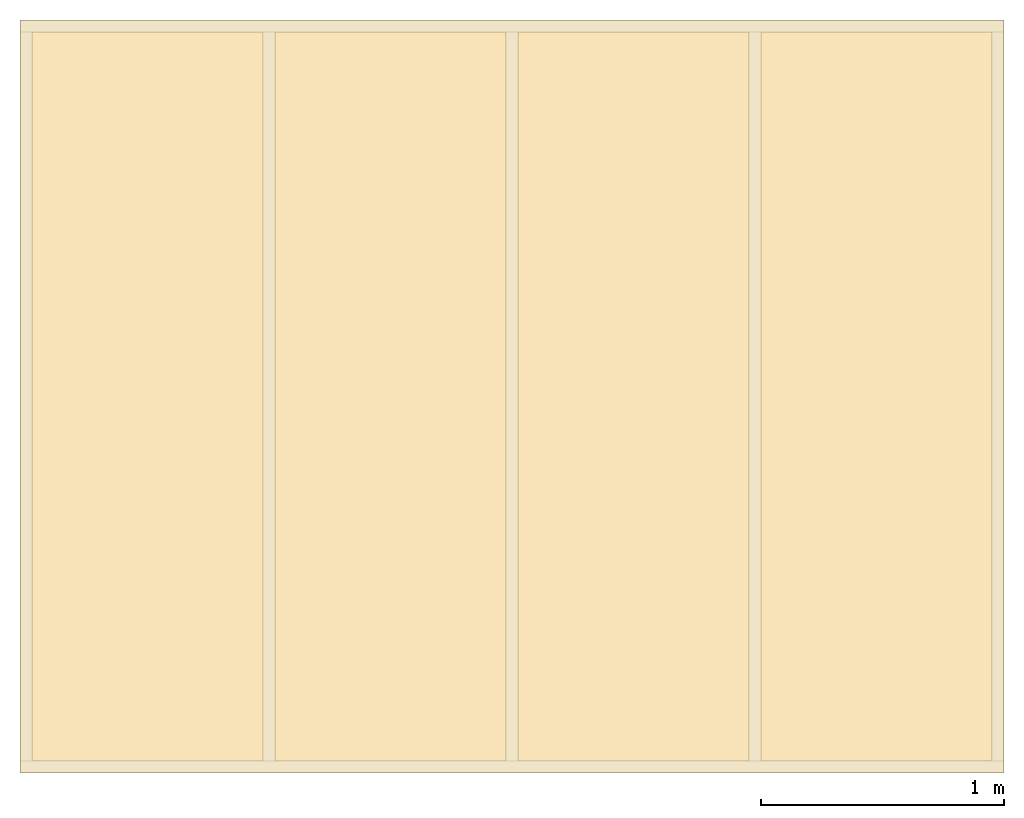
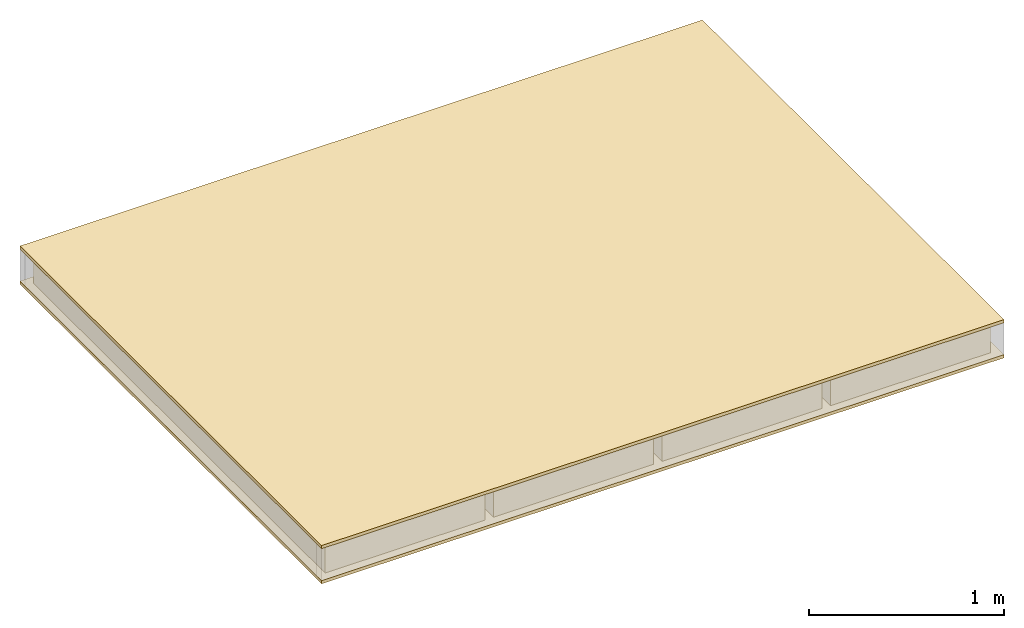
# One storey, part 2 of 2: 6 coverings.
"""IFC4 building model written with IfcOpenShell, lengths in millimetres."""

from ifc_helpers import new_model, si_unit, frame, origin_with_axes, origin_2d_with_axis, place, context, subcontext, project, spatial, indexed_curve, outline, extrude, element, save


model = new_model("IFC4")

# Units and contexts
model_context_1 = context("Model", 3, precision=1e-05, world=origin_with_axes())
model_context_2 = context("Model", 3, precision=1e-05, world=origin_with_axes())
plan_context = context("Plan", 2, precision=1e-05, world=origin_2d_with_axis())
body_context = subcontext(model_context_1, "Body", "Model", "MODEL_VIEW")
ifc_project = project(units=[si_unit("AREAUNIT", "SQUARE_METRE"), si_unit("VOLUMEUNIT", "CUBIC_METRE"), si_unit("LENGTHUNIT", "METRE", prefix="MILLI")], contexts=[model_context_1, model_context_2, plan_context])

# Site, building, storey
site = spatial("IfcSite", under=ifc_project)
building = spatial("IfcBuilding", under=site, Name="Building A")
storey = spatial("IfcBuildingStorey", under=building, Name="Ground Floor")

# Coverings
for number, where, z_axis, x_axis, name in (
    (1, (-25.0, -25.0, -100.0), (0.0, 1.0, 0.0), (1.0, 1.0, 0.0), "insulation"),
    (2, (-25.0, -25.0, 120.0), (0.0, 1.0, 0.0), (1.0, 1.0, 0.0), "insulation"),
):
    element("IfcCovering", number, at=place(None, frame(where, z_axis=z_axis, x_axis=x_axis)), inside=storey, Name=name, context=body_context, shape_type="SweptSolid", body=[
        extrude(outline(indexed_curve([(0.0, 0.0), (0.0, 20.0), (4050.0, 20.0), (4050.0, 0.0), (0.0, 0.0)], self_intersect=False)), origin_with_axes(), (0.0, 0.0, 1.0), 3100.0),
    ])
for number, where, z_axis, x_axis, name in (
    (3, (25.0, 25.0, 100.0), (0.0, 1.0, 0.0), (1.0, 1.0, 0.0), "insulation"),
    (4, (1025.0, 25.0, 100.0), (0.0, 1.0, 0.0), (1.0, 1.0, 0.0), "insulation"),
    (5, (2025.0, 25.0, 100.0), (0.0, 1.0, 0.0), (1.0, 1.0, 0.0), "insulation"),
    (6, (3025.0, 25.0, 100.0), (0.0, 1.0, 0.0), (1.0, 1.0, 0.0), "insulation"),
):
    element("IfcCovering", number, at=place(None, frame(where, z_axis=z_axis, x_axis=x_axis)), inside=storey, Name=name, context=body_context, shape_type="SweptSolid", body=[
        extrude(outline(indexed_curve([(0.0, 0.0), (0.0, 200.0), (950.0, 200.0), (950.0, 0.0), (0.0, 0.0)], self_intersect=False)), origin_with_axes(), (0.0, 0.0, 1.0), 3000.0),
    ])

save(model, "model.ifc")
